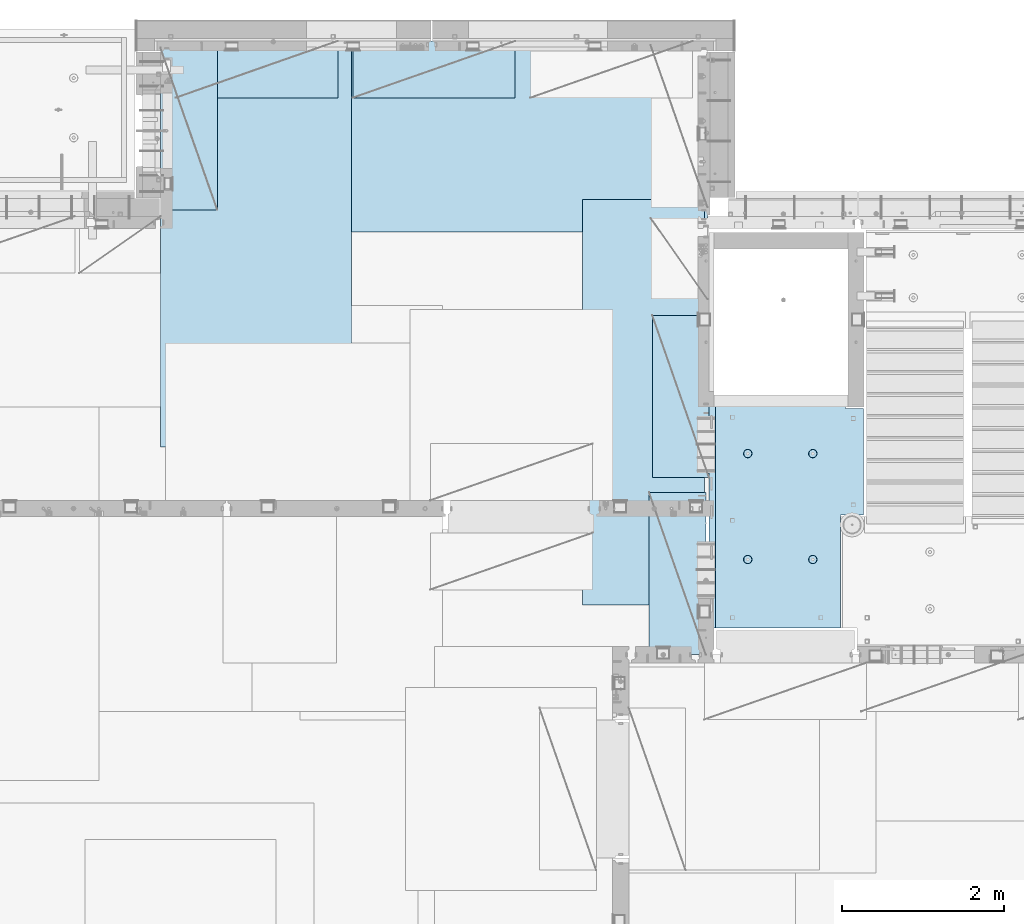
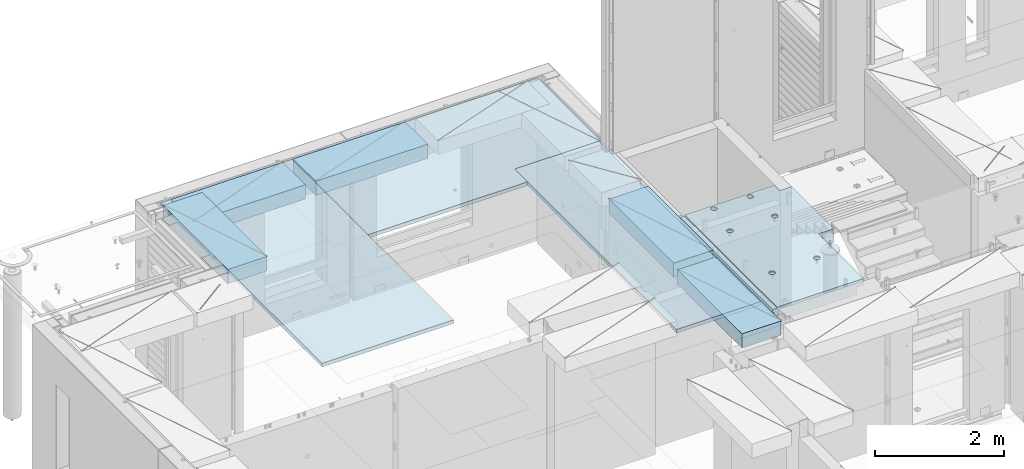
# One storey, part 205 of 352: 8 plates, 1 slab, 9 elements without a shape of their own.
"""IFC2X3 building model written with IfcOpenShell, lengths in millimetres."""

from ifc_helpers import new_model, si_unit, frame, origin_with_axes, place, context, subcontext, project, spatial, faceted_brep, material, type_object, element, aggregate, save


model = new_model("IFC2X3")

# Units and contexts
model_context = context("Model", 3, precision=1e-05, world=origin_with_axes())
body_context = subcontext(model_context, "Body", "Model", "MODEL_VIEW")
ifc_project = project(units=[si_unit("LENGTHUNIT", "METRE", prefix="MILLI"), si_unit("AREAUNIT", "SQUARE_METRE"), si_unit("VOLUMEUNIT", "CUBIC_METRE"), si_unit("MASSUNIT", "GRAM", prefix="KILO"), si_unit("TIMEUNIT", "SECOND"), si_unit("PLANEANGLEUNIT", "RADIAN"), si_unit("SOLIDANGLEUNIT", "STERADIAN"), si_unit("THERMODYNAMICTEMPERATUREUNIT", "DEGREE_CELSIUS"), si_unit("LUMINOUSINTENSITYUNIT", "LUMEN")], contexts=[model_context])

# Site, building, storey
site_placement = place(None, origin_with_axes())
site = spatial("IfcSite", under=ifc_project, at=site_placement, CompositionType="ELEMENT")
building_placement = place(site_placement, origin_with_axes())
building = spatial("IfcBuilding", under=site, at=building_placement, CompositionType="ELEMENT")
storey_placement = place(building_placement, origin_with_axes())
storey = spatial("IfcBuildingStorey", under=building, at=storey_placement, Name="6", CompositionType="ELEMENT", Elevation=0.0)

# Assembly, slab
assembly_1_placement = place(storey_placement, origin_with_axes())
assembly_1 = element("IfcElementAssembly", 1, at=assembly_1_placement, inside=storey, AssemblyPlace="NOTDEFINED", PredefinedType="REINFORCEMENT_UNIT")
ifc_material_1 = material(Name="CONCRETE/C25/30")
slab_type = type_object("IfcSlabType", PredefinedType="NOTDEFINED")
slab_placement = place(assembly_1_placement, frame((19370.0122708302, 15509.9992031236, 99620.0), z_axis=(-0.999999999999509, -9.91000000794397e-07, 0.0), x_axis=(-1.19799915409591e-06, 0.999999999999282, 0.0)))
slab = element("IfcSlab", 2, at=slab_placement, type_object=slab_type, material=ifc_material_1, PredefinedType="FLOOR", context=body_context, shape_type="Brep", body=[
    faceted_brep([(0.00270234311210515, 30.0, 1600.01636881603), (700.003686840937, 30.0, 1600.01632471597), (700.003459213352, 30.0, 1410.0099940095), (0.0034592138545122, 30.0, 1410.0108326095), (700.003459213352, 130.0, 1410.0099940095), (700.003686840937, 50.0008724475629, 1600.01632471597), (700.003710793628, 50.0008724475629, 1620.01159965654), (700.003710793628, 130.0, 1620.01159965654), (0.00238143379829125, 130.0, 1410.01083261132), (2149.99368684227, 30.0, 1600.01623336659), (2149.99345921271, 30.0, 1410.00825692148), (1649.99345921307, 30.0, 1410.00885592148), (1649.99368684195, 30.0, 1600.01626486659), (1390.00354003907, -130.0, -1.24055077321827e-09), (0.0, -130.0, -3.63797880709171e-12), (0.0, -10.0, 0.0), (1390.00503210942, -10.0000000000582, -8.29459168016911e-10), (0.00020267313993827, -10.0000000000582, 119.999691808891), (1390.0049992294, -10.0000000000582, 120.000072670202), (1390.0049992294, 129.999999999942, 120.000072670202), (0.000202673141757259, 130.0, 119.999691808891), (1390.00354003907, 130.0, -1.24055077321827e-09), (1390.00305175782, -130.0, -279.993591308594), (1390.00350516116, 130.0, -19.9999273271205), (1390.00305175782, 130.0, -279.993591308594), (2704.99731446005, 130.0, -279.993808230734), (2704.99731446008, -130.0, -279.993645464809), (2704.99757802008, 130.0, -59.9936454649687), (2704.99757802008, -130.000000000015, -59.9936454649687), (2869.99708830242, -130.0, -59.9938431343799), (2869.99708830242, 130.0, -59.9938431343799), (2869.99538188219, 50.0011350165441, 1600.0161880065), (2869.99536132813, 50.0011350165441, 1620.01123046875), (2149.99371079323, 50.0010478963522, 1620.01135296499), (2149.99368684227, 50.0010478963377, 1600.0162333666), (2869.99536132813, -109.999999999985, 1620.01123046875), (0.00273611420016096, -109.999999999985, 1620.01171875), (0.0026009984267148, -109.999999999985, 1540.01171889739), (2869.99544356416, -109.999999999985, 1540.01180212718), (2869.99536132813, -49.9988649834559, 1620.01123046875), (0.00273611420016096, -49.9992122525582, 1620.01171875), (2869.99538188219, -49.9988649834559, 1600.01618800648), (0.00270234311210515, -49.9992122525582, 1600.01636881602), (2869.99544356416, -129.999999999985, 1540.01180212718), (2869.99536132813, 130.0, 1620.01123046875), (2149.99371079323, 130.0, 1620.01135296499), (2149.99345921271, 130.0, 1410.00825692148), (1649.99345921307, 130.0, 1410.00885592148), (1649.99371079351, 130.0, 1620.01143803163), (1649.99371079351, 50.0009873963572, 1620.01143803163), (1649.99368684195, 50.0009873963427, 1600.0162648666), (0.0026009984267148, -130.0, 1540.01171889739), (858.080152798024, -110.0, 1097.45747495204), (872.018574202059, -110.0, 1104.55943434983), (883.080174557956, -110.0, 1115.62100820216), (890.182167352177, -110.0, 1129.55941258986), (892.62936004754, -110.0, 1145.01025937688), (890.182204372413, -110.0, 1160.46111202734), (883.08024497463, -110.0, 1174.39953343137), (872.018671122296, -110.0, 1185.46113378727), (858.080266734594, -110.0, 1192.56312658148), (842.629419947572, -110.0, 1195.01031927685), (827.178567297122, -110.0, 1192.56316360172), (813.240145893089, -110.0, 1185.46120420394), (802.178545537192, -110.0, 1174.3996303516), (795.076552742968, -110.0, 1160.46122596391), (792.629360047609, -110.0, 1145.01037917688), (795.076515722732, -110.0, 1129.55952652643), (802.178475120518, -110.0, 1115.62110512239), (813.240048972852, -110.0, 1104.5595047665), (827.178453360551, -110.0, 1097.45751197228), (842.629300147573, -110.0, 1095.01031927692), (858.782461559409, -130.0, 1095.29598202818), (842.629297424846, -130.0, 1092.73759200419), (873.354447572716, -130.0, 1102.72075776224), (884.918847944788, -130.0, 1114.28513042604), (892.343658593298, -130.0, 1128.85709864954), (894.902087320264, -130.0, 1145.01025665415), (892.34369729627, -130.0, 1161.16342078871), (884.918921562221, -130.0, 1175.73540680203), (873.354548898418, -130.0, 1187.29980717409), (858.782580674915, -130.0, 1194.72461782261), (842.629422670299, -130.0, 1197.28304654957), (826.476258535738, -130.0, 1194.72465652558), (811.90427252243, -130.0, 1187.29988079152), (800.339872150354, -130.0, 1175.73550812773), (792.915061501848, -130.0, 1161.16353990422), (790.356632774883, -130.0, 1145.01038189961), (792.915022798874, -130.0, 1128.85721776505), (800.339798532925, -130.0, 1114.28523175174), (811.904171196727, -130.0, 1102.72083137967), (826.476139420232, -130.0, 1095.29602073116), (858.08015281103, -110.0, 296.158841760913), (872.018574215066, -110.0, 303.2608011587), (883.080174570961, -110.0, 314.322375011034), (890.182167365187, -110.0, 328.26077939873), (892.629360060546, -110.0, 343.711626185755), (890.182204385423, -110.0, 359.162478836206), (883.080244987636, -110.0, 373.100900240239), (872.018671135302, -110.0, 384.16250059614), (858.0802667476, -110.0, 391.264493390358), (842.62941996058, -110.0, 393.711686085717), (827.178567310128, -110.0, 391.264530410594), (813.240145906095, -110.0, 384.16257101281), (802.178545550198, -110.0, 373.100997160473), (795.076552755974, -110.0, 359.162592772776), (792.629360060615, -110.0, 343.711745985755), (795.076515735738, -110.0, 328.2608933353), (802.178475133525, -110.0, 314.322471931268), (813.240048985859, -110.0, 303.26087157537), (827.178453373557, -110.0, 296.158878781149), (842.629300160579, -110.0, 293.71168608579), (858.782461572417, -130.0, 293.997348837052), (842.629297437852, -130.0, 291.438958813062), (873.354447585723, -130.0, 301.422124571109), (884.918847957797, -130.0, 312.98649723491), (892.343658606304, -130.0, 327.558465458413), (894.90208733327, -130.0, 343.711623463027), (892.343697309276, -130.0, 359.864787597588), (884.918921575227, -130.0, 374.436773610898), (873.354548911424, -130.0, 386.001173982968), (858.782580687921, -130.0, 393.425984631478), (842.629422683307, -130.0, 395.984413358441), (826.476258548744, -130.0, 393.426023334454), (811.904272535436, -130.0, 386.001247600398), (800.339872163362, -130.0, 374.4368749366), (792.915061514856, -130.0, 359.864906713094), (790.356632787889, -130.0, 343.711748708483), (792.915022811882, -130.0, 327.558584573919), (800.339798545931, -130.0, 312.986598560612), (811.904171209735, -130.0, 301.422198188538), (826.47613943324, -130.0, 293.997387540028), (2162.44895919675, -110.0, 1097.45754446905), (2176.38738060079, -110.0, 1104.55950386684), (2187.44898095669, -110.0, 1115.62107771917), (2194.55097375091, -110.0, 1129.55948210687), (2196.99816644627, -110.0, 1145.0103288939), (2194.55101077115, -110.0, 1160.46118154435), (2187.44905137336, -110.0, 1174.39960294838), (2176.38747752102, -110.0, 1185.46120330428), (2162.44907313332, -110.0, 1192.5631960985), (2146.9982263463, -110.0, 1195.01038879386), (2131.54737369585, -110.0, 1192.56323311873), (2117.60895229182, -110.0, 1185.46127372095), (2106.54735193592, -110.0, 1174.39969986862), (2099.4453591417, -110.0, 1160.46129548092), (2096.99816644634, -110.0, 1145.01044869389), (2099.44532212146, -110.0, 1129.55959604344), (2106.54728151925, -110.0, 1115.62117463941), (2117.60885537159, -110.0, 1104.55957428351), (2131.54725975928, -110.0, 1097.45758148929), (2146.9981065463, -110.0, 1095.01038879393), (2163.15126795814, -130.0, 1095.2960515452), (2146.99810382357, -130.0, 1092.73766152121), (2177.72325397145, -130.0, 1102.72082727925), (2189.28765434352, -130.0, 1114.28519994305), (2196.71246499203, -130.0, 1128.85716816655), (2199.27089371899, -130.0, 1145.01032617117), (2196.71250369501, -130.0, 1161.16349030573), (2189.28772796095, -130.0, 1175.73547631904), (2177.72335529715, -130.0, 1187.29987669111), (2163.15138707365, -130.0, 1194.72468733962), (2146.99822906903, -130.0, 1197.28311606658), (2130.84506493447, -130.0, 1194.72472604259), (2116.27307892116, -130.0, 1187.29995030854), (2104.70867854909, -130.0, 1175.73557764474), (2097.28386790058, -130.0, 1161.16360942123), (2094.72543917361, -130.0, 1145.01045141662), (2097.2838291976, -130.0, 1128.85728728206), (2104.70860493166, -130.0, 1114.28530126875), (2116.27297759546, -130.0, 1102.72090089668), (2130.84494581896, -130.0, 1095.29609024817), (2162.44895913772, -110.0, 296.158911320326), (2176.38738054176, -110.0, 303.260870718113), (2187.44898089765, -110.0, 314.322444570447), (2194.55097369188, -110.0, 328.260848958147), (2196.99816638724, -110.0, 343.711695745169), (2194.55101071211, -110.0, 359.162548395623), (2187.44905131433, -110.0, 373.100969799652), (2176.38747746199, -110.0, 384.162570155553), (2162.44907307429, -110.0, 391.264562949771), (2146.99822628727, -110.0, 393.711755645134), (2131.54737363682, -110.0, 391.264599970007), (2117.60895223279, -110.0, 384.162640572227), (2106.54735187689, -110.0, 373.10106671989), (2099.44535908267, -110.0, 359.162662332194), (2096.99816638731, -110.0, 343.711815545168), (2099.44532206243, -110.0, 328.260962894718), (2106.54728146021, -110.0, 314.322541490685), (2117.60885531255, -110.0, 303.260941134788), (2131.54725970025, -110.0, 296.158948340562), (2146.99810648727, -110.0, 293.711755645207), (2163.15126789911, -130.0, 293.997418396466), (2146.99810376454, -130.0, 291.439028372479), (2177.72325391241, -130.0, 301.422194130522), (2189.28765428449, -130.0, 312.986566794323), (2196.712464933, -130.0, 327.558535017826), (2199.27089365996, -130.0, 343.711693022444), (2196.71250363597, -130.0, 359.864857157001), (2189.28772790192, -130.0, 374.436843170311), (2177.72335523811, -130.0, 386.001243542381), (2163.15138701461, -130.0, 393.426054190892), (2146.99822901, -130.0, 395.984482917858), (2130.84506487544, -130.0, 393.426092893867), (2116.27307886213, -130.0, 386.001317159811), (2104.70867849006, -130.0, 374.436944496014), (2097.28386784155, -130.0, 359.864976272507), (2094.72543911458, -130.0, 343.711818267897), (2097.28382913857, -130.0, 327.558654133332), (2104.70860487263, -130.0, 312.986668120026), (2116.27297753642, -130.0, 301.422267747952), (2130.84494575993, -130.0, 293.997457099442), (2805.44844412025, -130.0, 362.453408379821), (2805.44844412025, 130.0, 362.453408379821), (2789.9975914698, 130.0, 360.006252704694), (2789.9975914698, -130.0, 360.006252704694), (2819.38686552428, -130.0, 369.555367777604), (2819.38686552428, 130.0, 369.555367777604), (2830.44846588018, -130.0, 380.616941629942), (2830.44846588018, 130.0, 380.616941629942), (2837.5504586744, -130.0, 394.555346017638), (2837.5504586744, 130.0, 394.555346017638), (2839.99765136976, -130.0, 410.006192804663), (2839.99765136976, 130.0, 410.006192804663), (2837.55049569464, -130.0, 425.457045455114), (2837.55049569464, 130.0, 425.457045455114), (2830.44853629686, -130.0, 439.395466859147), (2830.44853629686, 130.0, 439.395466859147), (2819.38696244451, -130.0, 450.457067215044), (2819.38696244451, 130.0, 450.457067215044), (2805.44855805682, -130.0, 457.559060009266), (2805.44855805682, 130.0, 457.559060009266), (2789.9977112698, -130.0, 460.006252704625), (2789.9977112698, 130.0, 460.006252704625), (2774.54685861935, -130.0, 457.559097029502), (2774.54685861935, 130.0, 457.559097029502), (2760.60843721531, -130.0, 450.457137631718), (2760.60843721531, 130.0, 450.457137631718), (2749.54683685942, -130.0, 439.395563779381), (2749.54683685942, 130.0, 439.395563779381), (2742.44484406519, -130.0, 425.457159391684), (2742.44484406519, 130.0, 425.457159391684), (2739.99765136983, -130.0, 410.006312604663), (2739.99765136983, 130.0, 410.006312604663), (2742.44480704495, -130.0, 394.555459954208), (2742.44480704495, 130.0, 394.555459954208), (2749.54676644274, -130.0, 380.617038550175), (2749.54676644274, 130.0, 380.617038550175), (2760.60834029508, -130.0, 369.555438194278), (2760.60834029508, 130.0, 369.555438194278), (2774.54674468278, -130.0, 362.453445400057), (2774.54674468278, 130.0, 362.453445400057), (2760.60911899507, -130.0, 1019.55543819397), (2749.54754514274, -130.0, 1030.61703854987), (2742.44558574495, -130.0, 1044.5554599539), (2739.99843006983, -130.0, 1060.00631260435), (2742.44562276519, -130.0, 1075.45715939137), (2749.54761555942, -130.0, 1089.39556377907), (2760.60921591531, -130.0, 1100.45713763141), (2774.54763731935, -130.0, 1107.55909702919), (2789.9984899698, -130.0, 1110.00625270432), (2805.44933675682, -130.0, 1107.55906000896), (2819.38774114452, -130.0, 1100.45706721473), (2830.44931499685, -130.0, 1089.39546685884), (2837.55127439463, -130.0, 1075.4570454548), (2839.99843006976, -130.0, 1060.00619280435), (2837.5512373744, -130.0, 1044.55534601733), (2830.44924458018, -130.0, 1030.61694162963), (2819.38764422428, -130.0, 1019.55536777729), (2805.44922282025, -130.0, 1012.45340837951), (2789.9983701698, -130.0, 1010.00625270438), (2774.54752338277, -130.0, 1012.45344539975), (2819.38764422428, 130.0, 1019.55536777729), (2805.44922282025, 130.0, 1012.45340837951), (2830.44924458018, 130.0, 1030.61694162963), (2837.5512373744, 130.0, 1044.55534601733), (2839.99843006976, 130.0, 1060.00619280435), (2837.55127439463, 130.0, 1075.4570454548), (2830.44931499685, 130.0, 1089.39546685884), (2819.38774114452, 130.0, 1100.45706721473), (2805.44933675682, 130.0, 1107.55906000896), (2789.9984899698, 130.0, 1110.00625270432), (2774.54763731935, 130.0, 1107.55909702919), (2760.60921591531, 130.0, 1100.45713763141), (2749.54761555942, 130.0, 1089.39556377907), (2742.44562276519, 130.0, 1075.45715939137), (2739.99843006983, 130.0, 1060.00631260435), (2742.44558574495, 130.0, 1044.5554599539), (2749.54754514274, 130.0, 1030.61703854987), (2760.60911899507, 130.0, 1019.55543819397), (2774.54752338277, 130.0, 1012.45344539975), (2789.9983701698, 130.0, 1010.00625270438)], [[[0, 1, 2, 3]], [[4, 2, 1, 5, 6, 7]], [[8, 3, 2, 4]], [[9, 10, 11, 12]], [[13, 14, 15, 16]], [[15, 17, 18, 16]], [[19, 18, 17, 20]], [[16, 18, 19, 21]], [[22, 13, 16, 21, 23, 24]], [[22, 24, 25, 26]], [[26, 25, 27, 28]], [[29, 28, 27, 30]], [[31, 32, 33, 34]], [[35, 36, 37, 38]], [[36, 35, 39, 40]], [[41, 42, 40, 39]], [[35, 38, 43, 29, 30, 44, 32, 31, 41, 39]], [[32, 44, 45, 33]], [[46, 10, 9, 34, 33, 45]], [[47, 11, 10, 46]], [[48, 49, 50, 12, 11, 47]], [[49, 48, 7, 6]], [[50, 49, 6, 5]], [[42, 41, 31, 34, 9, 12, 50, 5, 1, 0]], [[20, 17, 15, 14, 51, 37, 36, 40, 42, 0, 3, 8]], [[43, 38, 37, 51]], [[52, 53, 54, 55, 56, 57, 58, 59, 60, 61, 62, 63, 64, 65, 66, 67, 68, 69, 70, 71]], [[72, 52, 71, 73]], [[74, 53, 52, 72]], [[75, 54, 53, 74]], [[76, 55, 54, 75]], [[77, 56, 55, 76]], [[78, 57, 56, 77]], [[79, 58, 57, 78]], [[80, 59, 58, 79]], [[81, 60, 59, 80]], [[82, 61, 60, 81]], [[83, 62, 61, 82]], [[84, 63, 62, 83]], [[85, 64, 63, 84]], [[86, 65, 64, 85]], [[87, 66, 65, 86]], [[88, 67, 66, 87]], [[89, 68, 67, 88]], [[90, 69, 68, 89]], [[91, 70, 69, 90]], [[73, 71, 70, 91]], [[92, 93, 94, 95, 96, 97, 98, 99, 100, 101, 102, 103, 104, 105, 106, 107, 108, 109, 110, 111]], [[112, 92, 111, 113]], [[114, 93, 92, 112]], [[115, 94, 93, 114]], [[116, 95, 94, 115]], [[117, 96, 95, 116]], [[118, 97, 96, 117]], [[119, 98, 97, 118]], [[120, 99, 98, 119]], [[121, 100, 99, 120]], [[122, 101, 100, 121]], [[123, 102, 101, 122]], [[124, 103, 102, 123]], [[125, 104, 103, 124]], [[126, 105, 104, 125]], [[127, 106, 105, 126]], [[128, 107, 106, 127]], [[129, 108, 107, 128]], [[130, 109, 108, 129]], [[131, 110, 109, 130]], [[113, 111, 110, 131]], [[132, 133, 134, 135, 136, 137, 138, 139, 140, 141, 142, 143, 144, 145, 146, 147, 148, 149, 150, 151]], [[152, 132, 151, 153]], [[154, 133, 132, 152]], [[155, 134, 133, 154]], [[156, 135, 134, 155]], [[157, 136, 135, 156]], [[158, 137, 136, 157]], [[159, 138, 137, 158]], [[160, 139, 138, 159]], [[161, 140, 139, 160]], [[162, 141, 140, 161]], [[163, 142, 141, 162]], [[164, 143, 142, 163]], [[165, 144, 143, 164]], [[166, 145, 144, 165]], [[167, 146, 145, 166]], [[168, 147, 146, 167]], [[169, 148, 147, 168]], [[170, 149, 148, 169]], [[171, 150, 149, 170]], [[153, 151, 150, 171]], [[172, 173, 174, 175, 176, 177, 178, 179, 180, 181, 182, 183, 184, 185, 186, 187, 188, 189, 190, 191]], [[192, 172, 191, 193]], [[194, 173, 172, 192]], [[195, 174, 173, 194]], [[196, 175, 174, 195]], [[197, 176, 175, 196]], [[198, 177, 176, 197]], [[199, 178, 177, 198]], [[200, 179, 178, 199]], [[201, 180, 179, 200]], [[202, 181, 180, 201]], [[203, 182, 181, 202]], [[204, 183, 182, 203]], [[205, 184, 183, 204]], [[206, 185, 184, 205]], [[207, 186, 185, 206]], [[208, 187, 186, 207]], [[209, 188, 187, 208]], [[210, 189, 188, 209]], [[211, 190, 189, 210]], [[193, 191, 190, 211]], [[212, 213, 214, 215]], [[216, 217, 213, 212]], [[218, 219, 217, 216]], [[220, 221, 219, 218]], [[222, 223, 221, 220]], [[224, 225, 223, 222]], [[226, 227, 225, 224]], [[228, 229, 227, 226]], [[230, 231, 229, 228]], [[232, 233, 231, 230]], [[234, 235, 233, 232]], [[236, 237, 235, 234]], [[238, 239, 237, 236]], [[240, 241, 239, 238]], [[242, 243, 241, 240]], [[244, 245, 243, 242]], [[246, 247, 245, 244]], [[248, 249, 247, 246]], [[250, 251, 249, 248]], [[215, 214, 251, 250]], [[14, 13, 22, 26, 28, 29, 43, 51], [252, 253, 254, 255, 256, 257, 258, 259, 260, 261, 262, 263, 264, 265, 266, 267, 268, 269, 270, 271], [248, 246, 244, 242, 240, 238, 236, 234, 232, 230, 228, 226, 224, 222, 220, 218, 216, 212, 215, 250], [210, 209, 208, 207, 206, 205, 204, 203, 202, 201, 200, 199, 198, 197, 196, 195, 194, 192, 193, 211], [170, 169, 168, 167, 166, 165, 164, 163, 162, 161, 160, 159, 158, 157, 156, 155, 154, 152, 153, 171], [130, 129, 128, 127, 126, 125, 124, 123, 122, 121, 120, 119, 118, 117, 116, 115, 114, 112, 113, 131], [90, 89, 88, 87, 86, 85, 84, 83, 82, 81, 80, 79, 78, 77, 76, 75, 74, 72, 73, 91]], [[268, 272, 273, 269]], [[267, 274, 272, 268]], [[266, 275, 274, 267]], [[265, 276, 275, 266]], [[264, 277, 276, 265]], [[263, 278, 277, 264]], [[262, 279, 278, 263]], [[261, 280, 279, 262]], [[260, 281, 280, 261]], [[259, 282, 281, 260]], [[258, 283, 282, 259]], [[257, 284, 283, 258]], [[256, 285, 284, 257]], [[255, 286, 285, 256]], [[254, 287, 286, 255]], [[253, 288, 287, 254]], [[252, 289, 288, 253]], [[271, 290, 289, 252]], [[270, 291, 290, 271]], [[269, 273, 291, 270]], [[48, 47, 46, 45, 44, 30, 27, 25, 24, 23, 21, 19, 20, 8, 4, 7], [272, 274, 275, 276, 277, 278, 279, 280, 281, 282, 283, 284, 285, 286, 287, 288, 289, 290, 291, 273], [217, 219, 221, 223, 225, 227, 229, 231, 233, 235, 237, 239, 241, 243, 245, 247, 249, 251, 214, 213]]]),
])
aggregate(assembly_1, [slab])

# Assembly, plate
assembly_2_placement = place(storey_placement, origin_with_axes())
assembly_2 = element("IfcElementAssembly", 3, at=assembly_2_placement, inside=storey, Name="Steel Assembly", AssemblyPlace="NOTDEFINED", PredefinedType="NOTDEFINED")
ifc_material_2 = material()
plate_type_1 = type_object("IfcPlateType", PredefinedType="NOTDEFINED")
plate_1_placement = place(assembly_2_placement, frame((12729.9998779297, 22740.0009765625, 99695.1), z_axis=(1.0, 0.0, 0.0), x_axis=(0.0, -1.0, 0.0)))
plate_1 = element("IfcPlate", 4, at=plate_1_placement, type_object=plate_type_1, material=ifc_material_2, context=body_context, shape_type="Brep", body=[
    faceted_brep([(0.0, -35.0, 0.0), (0.0, -35.0, 5000.0), (0.0, 35.0, 5000.0), (0.0, 35.0, 0.0), (2349.99951171875, -35.0, 5000.0), (2349.99951171875, 35.0, 5000.0), (2350.0, -35.0, 0.0), (2350.0, 35.0, 0.0)], [[[0, 1, 2, 3]], [[1, 4, 5, 2]], [[4, 6, 7, 5]], [[6, 0, 3, 7]], [[5, 7, 3, 2]], [[6, 4, 1, 0]]]),
])
aggregate(assembly_2, [plate_1])

assembly_3_placement = place(storey_placement, origin_with_axes())
assembly_3 = element("IfcElementAssembly", 5, at=assembly_3_placement, inside=storey, Name="Steel Assembly", AssemblyPlace="NOTDEFINED", PredefinedType="NOTDEFINED")
plate_2_placement = place(assembly_3_placement, frame((13340.0, 22740.0, 99695.1), z_axis=(0.0, -1.0, 0.0), x_axis=(-1.0, 3.00000001838171e-08, 0.0)))
plate_2 = element("IfcPlate", 6, at=plate_2_placement, type_object=plate_type_1, material=ifc_material_2, context=body_context, shape_type="Brep", body=[
    faceted_brep([(0.0, -35.0, 0.0), (0.0, -35.0, 5000.0), (0.0, 35.0, 5000.0), (0.0, 35.0, 0.0), (2349.99951171875, -35.0, 5000.0), (2349.99951171875, 35.0, 5000.0), (2350.0, -35.0, 0.0), (2350.0, 35.0, 0.0)], [[[0, 1, 2, 3]], [[1, 4, 5, 2]], [[4, 6, 7, 5]], [[6, 0, 3, 7]], [[5, 7, 3, 2]], [[6, 4, 1, 0]]]),
])
aggregate(assembly_3, [plate_2])

assembly_4_placement = place(storey_placement, origin_with_axes())
assembly_4 = element("IfcElementAssembly", 7, at=assembly_4_placement, inside=storey, Name="Steel Assembly", AssemblyPlace="NOTDEFINED", PredefinedType="NOTDEFINED")
plate_type_2 = type_object("IfcPlateType", PredefinedType="NOTDEFINED")
plate_3_placement = place(assembly_4_placement, frame((17690.0000122641, 20790.0, 99695.1000003815), z_axis=(0.0, -1.0, 0.0), x_axis=(-1.0, 3.00000001838171e-08, 0.0)))
plate_3 = element("IfcPlate", 8, at=plate_3_placement, type_object=plate_type_2, material=ifc_material_2, context=body_context, shape_type="Brep", body=[
    faceted_brep([(0.0, -35.0, 0.0), (0.0, -35.0, 5000.0), (0.0, 35.0, 5000.0), (0.0, 35.0, 0.0), (1499.99951171875, -35.0, 5000.0), (1499.99951171875, 35.0, 5000.0), (1500.0, -35.0, 0.0), (1500.0, 35.0, 0.0)], [[[0, 1, 2, 3]], [[1, 4, 5, 2]], [[4, 6, 7, 5]], [[6, 0, 3, 7]], [[5, 7, 3, 2]], [[6, 4, 1, 0]]]),
])
aggregate(assembly_4, [plate_3])

assembly_5_placement = place(storey_placement, origin_with_axes())
assembly_5 = element("IfcElementAssembly", 9, at=assembly_5_placement, inside=storey, Name="Steel Assembly", AssemblyPlace="NOTDEFINED", PredefinedType="NOTDEFINED")
plate_type_3 = type_object("IfcPlateType", PredefinedType="NOTDEFINED")
plate_4_placement = place(assembly_5_placement, frame((17750.0001220703, 17360.0, 99595.3), z_axis=(-1.0, 3.00000001838171e-08, 0.0), x_axis=(0.0, 1.0, 0.0)))
plate_4 = element("IfcPlate", 10, at=plate_4_placement, type_object=plate_type_3, material=ifc_material_2, Name="RE1", context=body_context, shape_type="Brep", body=[
    faceted_brep([(1.81898940354586e-12, -135.0, 1.81898940354586e-12), (0.0, -135.0, 699.999999999996), (0.0, 135.0, 699.999999999996), (1.81898940354586e-12, 135.0, 1.81898940354586e-12), (1999.99951171875, -135.0, 699.999999999993), (1999.99951171875, 135.0, 699.999999999993), (2000.0, -135.0, -3.63797880709171e-12), (2000.0, 135.0, -3.63797880709171e-12)], [[[0, 1, 2, 3]], [[1, 4, 5, 2]], [[4, 6, 7, 5]], [[6, 0, 3, 7]], [[5, 7, 3, 2]], [[6, 4, 1, 0]]]),
])
aggregate(assembly_5, [plate_4])

assembly_6_placement = place(storey_placement, origin_with_axes())
assembly_6 = element("IfcElementAssembly", 11, at=assembly_6_placement, inside=storey, Name="Steel Assembly", AssemblyPlace="NOTDEFINED", PredefinedType="NOTDEFINED")
plate_5_placement = place(assembly_6_placement, frame((17710.0001220703, 15180.0, 99595.3), z_axis=(-1.0, 3.00000001838171e-08, 0.0), x_axis=(0.0, 1.0, 0.0)))
plate_5 = element("IfcPlate", 12, at=plate_5_placement, type_object=plate_type_3, material=ifc_material_2, Name="RE1", context=body_context, shape_type="Brep", body=[
    faceted_brep([(1.81898940354586e-12, -135.0, 1.81898940354586e-12), (0.0, -135.0, 699.999999999996), (0.0, 135.0, 699.999999999996), (1.81898940354586e-12, 135.0, 1.81898940354586e-12), (1999.99951171875, -135.0, 699.999999999993), (1999.99951171875, 135.0, 699.999999999993), (2000.0, -135.0, -3.63797880709171e-12), (2000.0, 135.0, -3.63797880709171e-12)], [[[0, 1, 2, 3]], [[1, 4, 5, 2]], [[4, 6, 7, 5]], [[6, 0, 3, 7]], [[5, 7, 3, 2]], [[6, 4, 1, 0]]]),
])
aggregate(assembly_6, [plate_5])

assembly_7_placement = place(storey_placement, origin_with_axes())
assembly_7 = element("IfcElementAssembly", 13, at=assembly_7_placement, inside=storey, Name="Steel Assembly", AssemblyPlace="NOTDEFINED", PredefinedType="NOTDEFINED")
plate_6_placement = place(assembly_7_placement, frame((13175.0, 22740.0001220703, 99595.3), z_axis=(0.0, -1.0, 0.0), x_axis=(-1.0, 3.00000001838171e-08, 0.0)))
plate_6 = element("IfcPlate", 14, at=plate_6_placement, type_object=plate_type_3, material=ifc_material_2, Name="RE1", context=body_context, shape_type="Brep", body=[
    faceted_brep([(1.81898940354586e-12, -135.0, 1.81898940354586e-12), (0.0, -135.0, 699.999999999996), (0.0, 135.0, 699.999999999996), (1.81898940354586e-12, 135.0, 1.81898940354586e-12), (1999.99951171875, -135.0, 699.999999999993), (1999.99951171875, 135.0, 699.999999999993), (2000.0, -135.0, -3.63797880709171e-12), (2000.0, 135.0, -3.63797880709171e-12)], [[[0, 1, 2, 3]], [[1, 4, 5, 2]], [[4, 6, 7, 5]], [[6, 0, 3, 7]], [[5, 7, 3, 2]], [[6, 4, 1, 0]]]),
])
aggregate(assembly_7, [plate_6])

assembly_8_placement = place(storey_placement, origin_with_axes())
assembly_8 = element("IfcElementAssembly", 15, at=assembly_8_placement, inside=storey, Name="Steel Assembly", AssemblyPlace="NOTDEFINED", PredefinedType="NOTDEFINED")
plate_7_placement = place(assembly_8_placement, frame((15360.0, 22740.0001220703, 99595.3), z_axis=(0.0, -1.0, 0.0), x_axis=(-1.0, 3.00000001838171e-08, 0.0)))
plate_7 = element("IfcPlate", 16, at=plate_7_placement, type_object=plate_type_3, material=ifc_material_2, Name="RE1", context=body_context, shape_type="Brep", body=[
    faceted_brep([(1.81898940354586e-12, -135.0, 1.81898940354586e-12), (0.0, -135.0, 699.999999999996), (0.0, 135.0, 699.999999999996), (1.81898940354586e-12, 135.0, 1.81898940354586e-12), (1999.99951171875, -135.0, 699.999999999993), (1999.99951171875, 135.0, 699.999999999993), (2000.0, -135.0, -3.63797880709171e-12), (2000.0, 135.0, -3.63797880709171e-12)], [[[0, 1, 2, 3]], [[1, 4, 5, 2]], [[4, 6, 7, 5]], [[6, 0, 3, 7]], [[5, 7, 3, 2]], [[6, 4, 1, 0]]]),
])
aggregate(assembly_8, [plate_7])

assembly_9_placement = place(storey_placement, origin_with_axes())
assembly_9 = element("IfcElementAssembly", 17, at=assembly_9_placement, inside=storey, Name="Steel Assembly", AssemblyPlace="NOTDEFINED", PredefinedType="NOTDEFINED")
plate_8_placement = place(assembly_9_placement, frame((10989.9998779297, 22660.0, 99595.3), z_axis=(1.0, 0.0, 0.0), x_axis=(0.0, -1.0, 0.0)))
plate_8 = element("IfcPlate", 18, at=plate_8_placement, type_object=plate_type_3, material=ifc_material_2, Name="RE1", context=body_context, shape_type="Brep", body=[
    faceted_brep([(1.81898940354586e-12, -135.0, 1.81898940354586e-12), (0.0, -135.0, 699.999999999996), (0.0, 135.0, 699.999999999996), (1.81898940354586e-12, 135.0, 1.81898940354586e-12), (1999.99951171875, -135.0, 699.999999999993), (1999.99951171875, 135.0, 699.999999999993), (2000.0, -135.0, -3.63797880709171e-12), (2000.0, 135.0, -3.63797880709171e-12)], [[[0, 1, 2, 3]], [[1, 4, 5, 2]], [[4, 6, 7, 5]], [[6, 0, 3, 7]], [[5, 7, 3, 2]], [[6, 4, 1, 0]]]),
])
aggregate(assembly_9, [plate_8])

save(model, "model.ifc")
